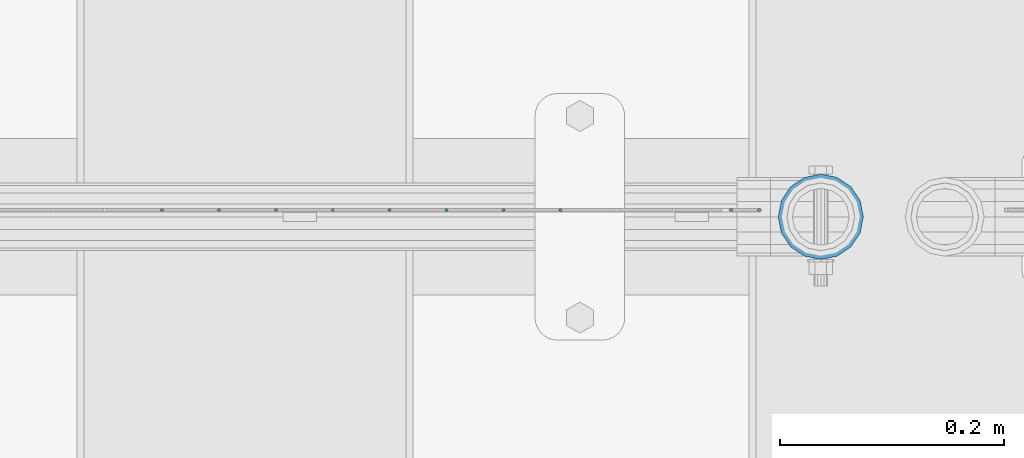
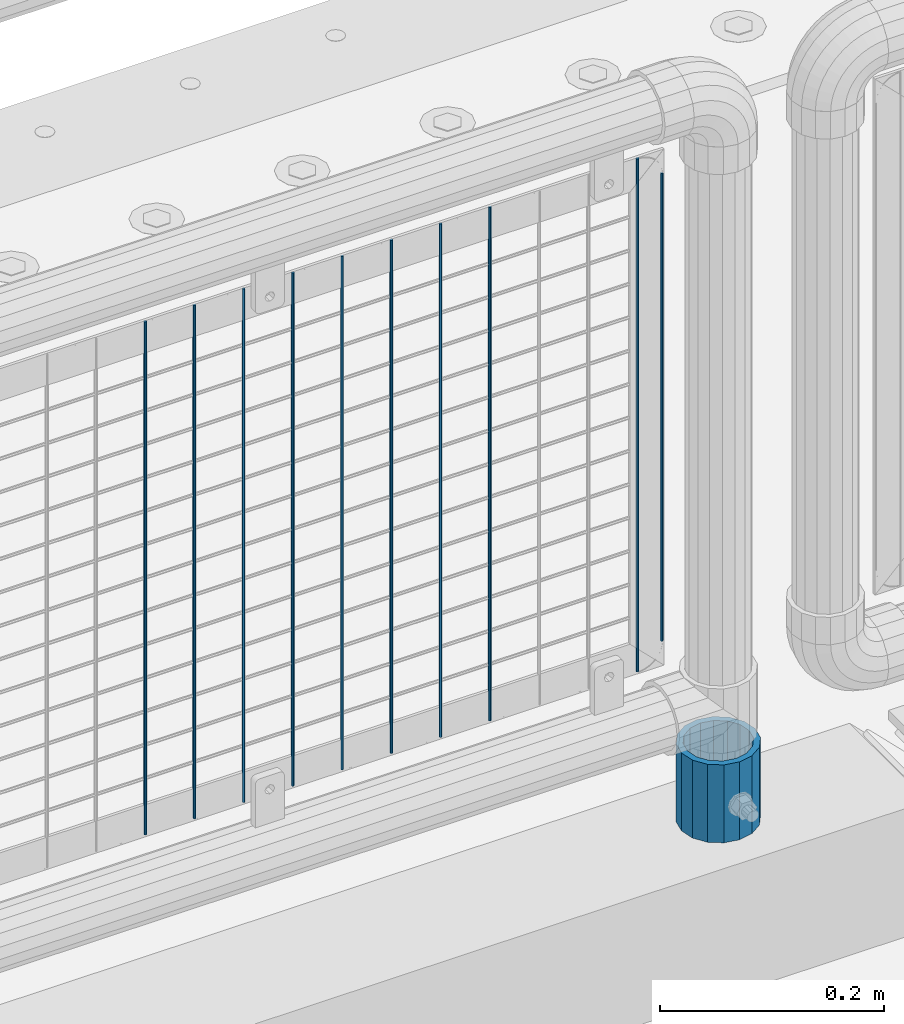
# One storey, part 105 of 242: 11 columns.
"""IFC2X3 building model written with IfcOpenShell, lengths in millimetres."""

from ifc_helpers import new_model, si_unit, frame, origin_with_axes, place, context, subcontext, project, spatial, faceted_brep, material, type_object, element, save


model = new_model("IFC2X3")

# Units and contexts
model_context = context("Model", 3, precision=1e-05, world=origin_with_axes())
body_context = subcontext(model_context, "Body", "Model", "MODEL_VIEW")
ifc_project = project(units=[si_unit("LENGTHUNIT", "METRE", prefix="MILLI"), si_unit("AREAUNIT", "SQUARE_METRE"), si_unit("VOLUMEUNIT", "CUBIC_METRE"), si_unit("MASSUNIT", "GRAM", prefix="KILO"), si_unit("TIMEUNIT", "SECOND"), si_unit("PLANEANGLEUNIT", "RADIAN"), si_unit("SOLIDANGLEUNIT", "STERADIAN"), si_unit("THERMODYNAMICTEMPERATUREUNIT", "DEGREE_CELSIUS"), si_unit("LUMINOUSINTENSITYUNIT", "LUMEN")], contexts=[model_context])

# Site, building, storey
site_placement = place(None, origin_with_axes())
site = spatial("IfcSite", under=ifc_project, at=site_placement, CompositionType="ELEMENT")
building_placement = place(site_placement, origin_with_axes())
building = spatial("IfcBuilding", under=site, at=building_placement, Name="Standard", CompositionType="ELEMENT")
storey_placement = place(building_placement, origin_with_axes())
storey = spatial("IfcBuildingStorey", under=building, at=storey_placement, Name="Undefined", CompositionType="ELEMENT", Elevation=0.0)

# Columns
ifc_material_1 = material(Name="Misc_Undefined")
column_type_1 = type_object("IfcColumnType", Name="D3", PredefinedType="NOTDEFINED")
for number, where, z_axis, x_axis in (
    (1, (-24098.382, -19329.5, 353.02), (-1.0, 0.0, 0.0), (0.0, 0.0, 1.0)),
    (2, (-24149.175, -19329.5, 353.02), (-1.0, 0.0, 0.0), (0.0, 0.0, 1.0)),
    (3, (-24199.968, -19329.5, 353.02), (-1.0, 0.0, 0.0), (0.0, 0.0, 1.0)),
    (4, (-24250.761, -19329.5, 353.02), (-1.0, 0.0, 0.0), (0.0, 0.0, 1.0)),
    (5, (-24301.554, -19329.5, 353.02), (-1.0, 0.0, 0.0), (0.0, 0.0, 1.0)),
    (6, (-23946.003, -19329.5, 353.02), (-1.0, 0.0, 0.0), (0.0, 0.0, 1.0)),
    (7, (-24352.347, -19329.5, 353.02), (-1.0, 0.0, 0.0), (0.0, 0.0, 1.0)),
    (8, (-24403.14, -19329.5, 353.02), (-1.0, 0.0, 0.0), (0.0, 0.0, 1.0)),
    (9, (-24453.933, -19329.5, 353.02), (-1.0, 0.0, 0.0), (0.0, 0.0, 1.0)),
):
    element("IfcColumn", number, at=place(storey_placement, frame(where, z_axis=z_axis, x_axis=x_axis)), inside=storey, type_object=column_type_1, material=ifc_material_1, ObjectType="D3", context=body_context, shape_type="Brep", body=[
        faceted_brep([(0.0, -1.50000000000364, 0.0), (-3.63797880709171e-12, -0.750000000003638, -1.29903810567669), (560.0, -0.75, -1.29903810567703), (560.0, -1.5, 0.0), (0.0, 0.749999999996362, -1.29903810567669), (560.0, 0.75, -1.29903810567703), (-3.63797880709171e-12, 1.49999999999636, 0.0), (560.0, 1.5, 0.0), (0.0, 0.749999999996362, 1.29903810567669), (560.0, 0.75, 1.29903810567703), (-3.63797880709171e-12, -0.750000000003638, 1.29903810567669), (560.0, -0.75, 1.29903810567703)], [[[0, 1, 2, 3]], [[1, 4, 5, 2]], [[4, 6, 7, 5]], [[6, 8, 9, 7]], [[8, 10, 11, 9]], [[10, 0, 3, 11]], [[5, 7, 9, 11, 3, 2]], [[10, 8, 6, 4, 1, 0]]]),
    ])
column_1_placement = place(storey_placement, frame((-23921.0, -19329.5, 378.02), z_axis=(-1.0, 0.0, 0.0), x_axis=(0.0, 0.0, 1.0)))
element("IfcColumn", 10, at=column_1_placement, inside=storey, type_object=column_type_1, material=ifc_material_1, ObjectType="D3", context=body_context, shape_type="Brep", body=[
    faceted_brep([(0.0, -1.50000000000364, 0.0), (-3.63797880709171e-12, -0.750000000003638, -1.29903810567669), (510.0, -0.75, -1.29903810567703), (510.0, -1.5, 0.0), (0.0, 0.749999999996362, -1.29903810567669), (510.0, 0.75, -1.29903810567703), (-3.63797880709171e-12, 1.49999999999636, 0.0), (510.0, 1.5, 0.0), (0.0, 0.749999999996362, 1.29903810567669), (510.0, 0.75, 1.29903810567703), (-3.63797880709171e-12, -0.750000000003638, 1.29903810567669), (510.0, -0.75, 1.29903810567703)], [[[0, 1, 2, 3]], [[1, 4, 5, 2]], [[4, 6, 7, 5]], [[6, 8, 9, 7]], [[8, 10, 11, 9]], [[10, 0, 3, 11]], [[5, 7, 9, 11, 3, 2]], [[10, 8, 6, 4, 1, 0]]]),
])
ifc_material_2 = material()
column_type_2 = type_object("IfcColumnType", PredefinedType="NOTDEFINED")
column_2_placement = place(storey_placement, frame((-23866.0, -19335.5, 168.02), z_axis=(0.0, 1.0, 0.0), x_axis=(0.0, 0.0, 1.0)))
element("IfcColumn", 11, at=column_2_placement, inside=storey, type_object=column_type_2, material=ifc_material_2, context=body_context, shape_type="Brep", body=[
    faceted_brep([(0.0, -31.75, 0.0), (0.0, -29.3331751572332, 12.1501989775934), (85.0, -29.3331751572332, 12.1501989775934), (85.0, -31.75, 0.0), (0.0, -22.4506403026717, 22.4506403026717), (85.0, -22.4506403026717, 22.4506403026717), (0.0, -12.1501989775934, 29.3331751572332), (85.0, -12.1501989775934, 29.3331751572332), (0.0, 0.0, 31.75), (85.0, 0.0, 31.75), (0.0, 12.1501989775934, 29.3331751572332), (85.0, 12.1501989775934, 29.3331751572332), (0.0, 22.4506403026717, 22.4506403026717), (85.0, 22.4506403026717, 22.4506403026717), (0.0, 29.3331751572332, 12.1501989775934), (85.0, 29.3331751572332, 12.1501989775934), (0.0, 31.75, 0.0), (85.0, 31.75, 0.0), (0.0, 29.3331751572332, -12.1501989775934), (85.0, 29.3331751572332, -12.1501989775934), (0.0, 22.4506403026717, -22.4506403026717), (85.0, 22.4506403026717, -22.4506403026717), (0.0, 12.1501989775934, -29.3331751572332), (85.0, 12.1501989775934, -29.3331751572332), (0.0, 0.0, -31.75), (85.0, 0.0, -31.75), (0.0, -12.1501989775934, -29.3331751572332), (85.0, -12.1501989775934, -29.3331751572332), (0.0, -22.4506403026717, -22.4506403026717), (85.0, -22.4506403026717, -22.4506403026717), (0.0, -29.3331751572332, -12.1501989775934), (85.0, -29.3331751572332, -12.1501989775934), (0.0, -38.0499999999993, 0.0), (0.0, -35.1536162120537, -14.5611046014928), (85.0, -35.1536162120537, -14.5611046014928), (85.0, -38.0499999999993, 0.0), (0.0, -26.9054130241493, -26.9054130241493), (85.0, -26.9054130241493, -26.9054130241493), (0.0, -14.5611046014928, -35.1536162120537), (85.0, -14.5611046014928, -35.1536162120537), (0.0, 0.0, -38.0499999999993), (85.0, 0.0, -38.0499999999993), (0.0, 14.5611046014928, -35.1536162120537), (85.0, 14.5611046014928, -35.1536162120537), (0.0, 26.9054130241493, -26.9054130241493), (85.0, 26.9054130241493, -26.9054130241493), (0.0, 35.1536162120537, -14.5611046014928), (85.0, 35.1536162120537, -14.5611046014928), (0.0, 38.0499999999993, 0.0), (85.0, 38.0499999999993, 0.0), (0.0, 35.1536162120537, 14.5611046014928), (85.0, 35.1536162120537, 14.5611046014928), (0.0, 26.9054130241493, 26.9054130241493), (85.0, 26.9054130241493, 26.9054130241493), (0.0, 14.5611046014928, 35.1536162120537), (85.0, 14.5611046014928, 35.1536162120537), (0.0, 0.0, 38.0499999999993), (85.0, 0.0, 38.0499999999993), (0.0, -14.5611046014928, 35.1536162120537), (85.0, -14.5611046014928, 35.1536162120537), (0.0, -26.9054130241493, 26.9054130241493), (85.0, -26.9054130241493, 26.9054130241493), (0.0, -35.1536162120537, 14.5611046014928), (85.0, -35.1536162120537, 14.5611046014928)], [[[0, 1, 2, 3]], [[1, 4, 5, 2]], [[4, 6, 7, 5]], [[6, 8, 9, 7]], [[8, 10, 11, 9]], [[10, 12, 13, 11]], [[12, 14, 15, 13]], [[14, 16, 17, 15]], [[16, 18, 19, 17]], [[18, 20, 21, 19]], [[20, 22, 23, 21]], [[22, 24, 25, 23]], [[24, 26, 27, 25]], [[26, 28, 29, 27]], [[28, 30, 31, 29]], [[30, 0, 3, 31]], [[32, 33, 34, 35]], [[33, 36, 37, 34]], [[36, 38, 39, 37]], [[38, 40, 41, 39]], [[40, 42, 43, 41]], [[42, 44, 45, 43]], [[44, 46, 47, 45]], [[46, 48, 49, 47]], [[48, 50, 51, 49]], [[50, 52, 53, 51]], [[52, 54, 55, 53]], [[54, 56, 57, 55]], [[56, 58, 59, 57]], [[58, 60, 61, 59]], [[60, 62, 63, 61]], [[62, 32, 35, 63]], [[37, 39, 41, 43, 45, 47, 49, 51, 53, 55, 57, 59, 61, 63, 35, 34], [5, 7, 9, 11, 13, 15, 17, 19, 21, 23, 25, 27, 29, 31, 3, 2]], [[62, 60, 58, 56, 54, 52, 50, 48, 46, 44, 42, 40, 38, 36, 33, 32], [30, 28, 26, 24, 22, 20, 18, 16, 14, 12, 10, 8, 6, 4, 1, 0]]]),
])

save(model, "model.ifc")
